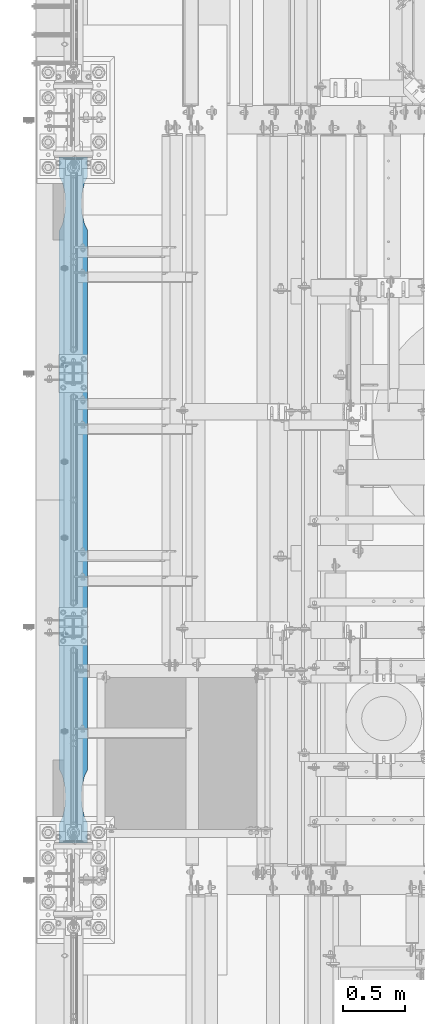
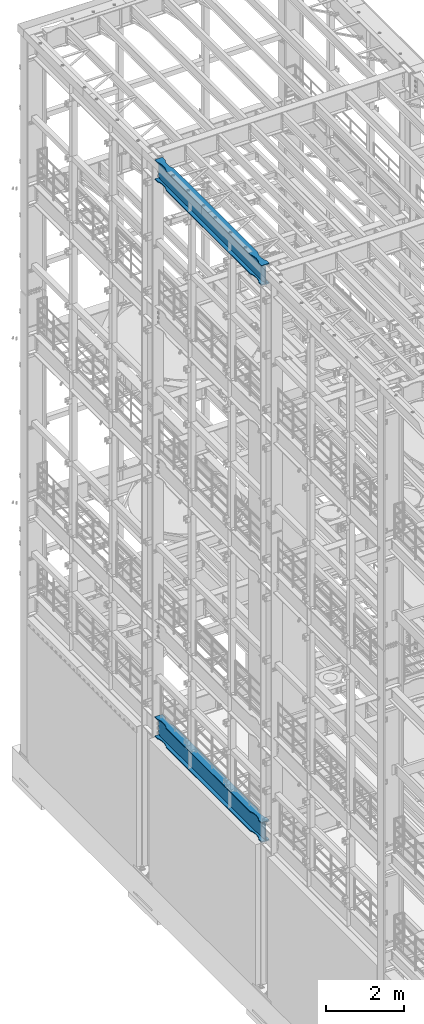
# One storey, part 1022 of 1876: 2 beams, 2 elements without a shape of their own.
"""IFC2X3 building model written with IfcOpenShell, lengths in millimetres."""

from ifc_helpers import new_model, si_unit, frame, origin_with_axes, place, context, subcontext, project, spatial, faceted_brep, material, type_object, element, aggregate, save


model = new_model("IFC2X3")

# Units and contexts
model_context = context("Model", 3, precision=1e-05, world=origin_with_axes())
body_context = subcontext(model_context, "Body", "Model", "MODEL_VIEW")
ifc_project = project(units=[si_unit("LENGTHUNIT", "METRE", prefix="MILLI"), si_unit("AREAUNIT", "SQUARE_METRE"), si_unit("VOLUMEUNIT", "CUBIC_METRE"), si_unit("MASSUNIT", "GRAM", prefix="KILO"), si_unit("TIMEUNIT", "SECOND"), si_unit("PLANEANGLEUNIT", "RADIAN"), si_unit("SOLIDANGLEUNIT", "STERADIAN"), si_unit("THERMODYNAMICTEMPERATUREUNIT", "DEGREE_CELSIUS"), si_unit("LUMINOUSINTENSITYUNIT", "LUMEN")], contexts=[model_context])

# Site, building, storey
site_placement = place(None, origin_with_axes())
site = spatial("IfcSite", under=ifc_project, at=site_placement, CompositionType="ELEMENT")
building_placement = place(site_placement, origin_with_axes())
building = spatial("IfcBuilding", under=site, at=building_placement, Name="Undefined", CompositionType="ELEMENT")
storey_placement = place(building_placement, origin_with_axes())
storey = spatial("IfcBuildingStorey", under=building, at=storey_placement, Name="Undefined", CompositionType="ELEMENT", Elevation=0.0)

# Assembly, beam
assembly_1_placement = place(storey_placement, origin_with_axes())
assembly_1 = element("IfcElementAssembly", 1, at=assembly_1_placement, inside=storey, Name="BEAM", AssemblyPlace="NOTDEFINED", PredefinedType="RIGID_FRAME")
ifc_material = material(Name="STEEL/A992")
beam_type = type_object("IfcBeamType", Name="W24X103", PredefinedType="NOTDEFINED")
beam_1_placement = place(assembly_1_placement, frame((0.0, 1524.0, 22244.05), z_axis=(0.0, 0.0, 1.0), x_axis=(0.0, 1.0, 0.0)))
beam_1 = element("IfcBeam", 2, at=beam_1_placement, type_object=beam_type, material=ifc_material, Name="BEAM", ObjectType="W24X103", context=body_context, shape_type="Brep", body=[
    faceted_brep([(306.3875, 7.14375, -250.825000000001), (298.45, -7.14375, -250.825000000001), (298.45, -7.14375, 250.825000000001), (306.3875, 7.14375, 250.825000000001), (5789.6125, 7.14375, 250.825000000001), (5797.55, -7.14375, 250.825000000001), (5797.55, -7.14375, -250.825000000001), (5789.6125, 7.14375, -250.825000000001), (5210.175, -114.3, -311.150000000001), (5210.175, -114.3, -285.75), (885.825008761703, -114.300009625517, -285.75), (885.825008761703, -114.3, -311.150000000001), (5259.2741470513, -88.8999992679901, -311.150000000001), (5259.2741470513, -88.8999992679901, -285.75), (5341.71315599965, -69.8863941921136, -311.150000000001), (5341.71315599965, -69.8863941921136, -285.75), (5426.0750039875, -63.5000040971918, -311.150000000001), (5426.0750039875, -63.5000040971918, -285.75), (5510.43685211057, -69.8863924058523, -311.150000000001), (5510.43685211057, -69.8863924058523, -285.75), (5592.87586146151, -88.8999957361821, -311.150000000001), (5592.87586146151, -88.8999957361821, -285.75), (5641.97500876196, -114.299992330618, -285.75), (5641.97500876196, -114.3, -311.150000000001), (5797.55, -114.3, -311.150000000001), (5782.88540094246, -114.299999277079, -285.75), (5210.175, -114.3, 285.75), (5210.175, -114.3, 311.150000000001), (885.825008761703, -114.300009625517, 311.150000000001), (885.825008761703, -114.3, 285.75), (5259.2741470513, -88.8999992679901, 285.75), (5259.2741470513, -88.8999992679901, 311.150000000001), (5341.71315599965, -69.8863941921136, 285.75), (5341.71315599965, -69.8863941921136, 311.150000000001), (5426.0750039875, -63.5000040971918, 285.75), (5426.0750039875, -63.5000040971918, 311.150000000001), (5510.43685211057, -69.8863924058523, 285.75), (5510.43685211057, -69.8863924058523, 311.150000000001), (5592.87586146151, -88.8999957361821, 285.75), (5592.87586146151, -88.8999957361821, 311.150000000001), (5641.97500876196, -114.299992330618, 311.150000000001), (5641.97500876196, -114.3, 285.75), (5797.55, -114.3, 285.75), (5782.88541369173, -114.29999927708, 311.150000000001), (5749.09000317383, -7.14375000000018, -285.35299987793), (5749.09000317383, 7.14375000000018, -285.35299987793), (5713.61774885072, 7.14375000000018, -269.000062630286), (5713.61774885072, -7.14375000000018, -269.000062630286), (5709.72754094452, 7.14375000000018, -265.703842989446), (5709.72754094452, -7.14375000000018, -265.703842989446), (5708.09487519741, 7.14375000000018, -260.873399528195), (5708.09487519741, -7.14375000000018, -260.873399528195), (5709.18761637614, 7.14375000000018, -255.89296800167), (5709.18761637614, -7.14375000000018, -255.89296800167), (5712.69262316711, 7.14375000000018, -252.189765486371), (5712.69262316711, -7.14375000000018, -252.189765486371), (5717.60548349907, 7.14375000000018, -250.825000000001), (5717.60548349907, -7.14375000000018, -250.825000000001), (5718.44048546451, 7.14375000000018, 250.825000000001), (5718.44048546451, -7.14375000000018, 250.825000000001), (5713.52762519576, 7.14375000000018, 252.189765448315), (5713.52762519576, -7.14375000000018, 252.189765448315), (5710.02261841062, 7.14375000000018, 255.892967871263), (5710.02261841062, -7.14375000000018, 255.892967871263), (5708.92987715069, 7.14375000000018, 260.873399307191), (5708.92987715069, -7.14375000000018, 260.873399307191), (5710.56254274408, 7.14375000000018, 265.703842745359), (5710.56254274408, -7.14375000000018, 265.703842745359), (5714.45275048114, 7.14375000000018, 269.000062475843), (5714.45275048114, -7.14375000000018, 269.000062475843), (5749.92500152588, 7.14375000000018, 285.35299987793), (5749.92500152588, -7.14375000000018, 285.35299987793), (5797.55, 7.14375000000018, 285.35299987793), (5797.55, -7.14375000000018, 285.35299987793), (5797.55, 7.14375000000018, 285.75), (5797.55, -7.14375000000018, 285.75), (5210.175, 114.3, 311.150000000001), (5210.175, 114.3, 285.75), (885.825008761703, 114.3, 285.75), (885.825008761703, 114.299990374483, 311.150000000001), (5259.2741470513, 88.8999992679901, 311.150000000001), (5259.2741470513, 88.8999992679901, 285.75), (5341.71315599965, 69.8863941921136, 311.150000000001), (5341.71315599965, 69.8863941921136, 285.75), (5426.0750039875, 63.5000040971918, 311.150000000001), (5426.0750039875, 63.5000040971918, 285.75), (5510.43685211057, 69.8863924058523, 311.150000000001), (5510.43685211057, 69.8863924058523, 285.75), (5592.87586146151, 88.8999957361821, 311.150000000001), (5592.87586146151, 88.8999957361821, 285.75), (5641.97500876196, 114.299992330618, 311.150000000001), (5641.97500876196, 114.3, 285.75), (5782.88541369173, 114.29999927708, 311.150000000001), (5797.55, 114.3, 285.75), (298.45, 7.14375000000018, 285.75), (298.45, 114.3, 285.75), (454.024999999921, 114.3, 285.75), (503.124147300347, 88.8999861106649, 285.75), (585.563156651265, 69.8863827803352, 285.75), (669.925004774302, 63.4999944716747, 285.75), (754.286852762112, 69.8863845665965, 285.75), (836.72586171043, 88.899989642473, 285.75), (454.024999999921, 114.3, 311.150000000001), (313.114586308271, 114.3, 311.150000000001), (503.124147300347, 88.8999861106649, 311.150000000001), (585.563156651265, 69.8863827803352, 311.150000000001), (669.925004774302, 63.4999944716747, 311.150000000001), (754.286852762112, 69.8863845665965, 311.150000000001), (836.72586171043, 88.899989642473, 311.150000000001), (313.114586308271, -114.3, 311.150000000001), (454.024999999921, -114.3, 311.150000000001), (503.124147300347, -88.9000053616992, 311.150000000001), (585.563156651265, -69.8864020313695, 311.150000000001), (669.925004774302, -63.5000137227089, 311.150000000001), (754.286852762112, -69.8864038176307, 311.150000000001), (836.72586171043, -88.9000088935072, 311.150000000001), (454.024999999921, -114.3, 285.75), (298.45, -114.3, 285.75), (503.124147300347, -88.9000053616992, 285.75), (585.563156651265, -69.8864020313695, 285.75), (669.925004774302, -63.5000137227089, 285.75), (754.286852762112, -69.8864038176307, 285.75), (836.72586171043, -88.9000088935072, 285.75), (298.45, -7.14375000000018, 285.75), (298.45, 7.14375000000018, 285.35299987793), (298.45, -7.14375000000018, 285.35299987793), (346.074998474121, 7.14375000000018, 285.35299987793), (346.074998474121, -7.14375000000018, 285.35299987793), (381.547249518856, 7.14375000000018, 269.000062475843), (381.547249518856, -7.14375000000018, 269.000062475843), (385.437457255921, 7.14375000000018, 265.703842745359), (385.437457255921, -7.14375000000018, 265.703842745359), (387.070122849314, 7.14375000000018, 260.873399307191), (387.070122849314, -7.14375000000018, 260.873399307191), (385.977381589376, 7.14375000000018, 255.892967871263), (385.977381589376, -7.14375000000018, 255.892967871263), (382.472374804242, 7.14375000000018, 252.189765448315), (382.472374804242, -7.14375000000018, 252.189765448315), (377.559514535493, 7.14375000000018, 250.825000000001), (377.559514535493, -7.14375000000018, 250.825000000001), (378.39451650093, 7.14375000000018, -250.825000000001), (378.39451650093, -7.14375000000018, -250.825000000001), (383.307376832887, 7.14375000000018, -252.189765486371), (383.307376832887, -7.14375000000018, -252.189765486371), (386.81238362386, 7.14375000000018, -255.89296800167), (386.81238362386, -7.14375000000018, -255.89296800167), (387.905124802588, 7.14375000000018, -260.873399528195), (387.905124802588, -7.14375000000018, -260.873399528195), (386.272459055476, 7.14375000000018, -265.703842989446), (386.272459055476, -7.14375000000018, -265.703842989446), (382.382251149282, 7.14375000000018, -269.000062630286), (382.382251149282, -7.14375000000018, -269.000062630286), (346.909996826172, 7.14375000000018, -285.35299987793), (346.909996826172, -7.14375000000018, -285.35299987793), (313.343799385621, 7.14375000000018, -285.35299987793), (313.343799385621, -7.14375000000018, -285.35299987793), (313.114599057541, -7.14375000000018, -285.75), (5782.88540094246, -7.14375000000018, -285.75), (5782.65620061438, -7.14375000000018, -285.35299987793), (5782.65620061438, 7.14375000000018, -285.35299987793), (5782.88540094246, 7.14375000000018, -285.75), (313.114599057541, 7.14375000000018, -285.75), (313.11459905754, 114.3, -285.75), (298.45, 114.3, -311.150000000001), (298.45, -114.3, -311.150000000001), (313.11459905754, -114.3, -285.75), (454.024999999921, -114.3, -311.150000000001), (454.024999999921, -114.3, -285.75), (503.124147300347, -88.9000053616992, -311.150000000001), (503.124147300347, -88.9000053616992, -285.75), (585.563156651265, -69.8864020313695, -311.150000000001), (585.563156651265, -69.8864020313695, -285.75), (669.925004774302, -63.5000137227089, -311.150000000001), (669.925004774302, -63.5000137227089, -285.75), (754.286852762112, -69.8864038176307, -311.150000000001), (754.286852762112, -69.8864038176307, -285.75), (836.72586171043, -88.9000088935072, -285.75), (5797.55, 114.3, -311.150000000001), (5782.88540094246, 114.299999277079, -285.75), (5641.97500876196, 114.3, -311.150000000001), (5641.97500876196, 114.299992330618, -285.75), (5592.87586146151, 88.8999957361821, -311.150000000001), (5592.87586146151, 88.8999957361821, -285.75), (5510.43685211057, 69.8863924058523, -311.150000000001), (5510.43685211057, 69.8863924058523, -285.75), (5426.0750039875, 63.5000040971918, -311.150000000001), (5426.0750039875, 63.5000040971918, -285.75), (5341.71315599965, 69.8863941921136, -311.150000000001), (5341.71315599965, 69.8863941921136, -285.75), (5259.2741470513, 88.8999992679901, -311.150000000001), (5259.2741470513, 88.8999992679901, -285.75), (5210.175, 114.3, -311.150000000001), (5210.175, 114.3, -285.75), (885.825008761703, 114.3, -311.150000000001), (885.825008761703, 114.299990374483, -285.75), (836.72586171043, 88.899989642473, -285.75), (754.286852762112, 69.8863845665965, -285.75), (669.925004774302, 63.4999944716747, -285.75), (585.563156651265, 69.8863827803352, -285.75), (503.124147300347, 88.8999861106649, -285.75), (454.024999999921, 114.3, -285.75), (454.024999999921, 114.3, -311.150000000001), (503.124147300347, 88.8999861106649, -311.150000000001), (585.563156651265, 69.8863827803352, -311.150000000001), (669.925004774302, 63.4999944716747, -311.150000000001), (754.286852762112, 69.8863845665965, -311.150000000001), (836.72586171043, 88.899989642473, -311.150000000001), (836.72586171043, -88.9000088935072, -311.150000000001)], [[[0, 1, 2, 3]], [[4, 5, 6, 7]], [[8, 9, 10, 11]], [[9, 8, 12, 13]], [[13, 12, 14, 15]], [[15, 14, 16, 17]], [[17, 16, 18, 19]], [[19, 18, 20, 21]], [[22, 21, 20, 23]], [[22, 23, 24, 25]], [[26, 27, 28, 29]], [[27, 26, 30, 31]], [[31, 30, 32, 33]], [[33, 32, 34, 35]], [[35, 34, 36, 37]], [[37, 36, 38, 39]], [[40, 39, 38, 41]], [[40, 41, 42, 43]], [[44, 45, 46, 47]], [[47, 46, 48, 49]], [[49, 48, 50, 51]], [[51, 50, 52, 53]], [[53, 52, 54, 55]], [[55, 54, 56, 57]], [[57, 56, 7, 6]], [[58, 59, 5, 4]], [[59, 58, 60, 61]], [[61, 60, 62, 63]], [[63, 62, 64, 65]], [[65, 64, 66, 67]], [[67, 66, 68, 69]], [[69, 68, 70, 71]], [[71, 70, 72, 73]], [[73, 72, 74, 75]], [[76, 77, 78, 79]], [[80, 81, 77, 76]], [[82, 83, 81, 80]], [[84, 85, 83, 82]], [[86, 87, 85, 84]], [[88, 89, 87, 86]], [[90, 91, 89, 88]], [[91, 90, 92, 93]], [[42, 75, 74, 93, 92, 43]], [[94, 95, 96, 97, 98, 99, 100, 101, 78, 77, 81, 83, 85, 87, 89, 91, 93, 74]], [[102, 96, 95, 103]], [[104, 97, 96, 102]], [[105, 98, 97, 104]], [[106, 99, 98, 105]], [[107, 100, 99, 106]], [[108, 101, 100, 107]], [[79, 78, 101, 108]], [[90, 88, 86, 84, 82, 80, 76, 79, 108, 107, 106, 105, 104, 102, 103, 109, 110, 111, 112, 113, 114, 115, 28, 27, 31, 33, 35, 37, 39, 40, 43, 92]], [[116, 110, 109, 117]], [[110, 116, 118, 111]], [[111, 118, 119, 112]], [[112, 119, 120, 113]], [[113, 120, 121, 114]], [[114, 121, 122, 115]], [[28, 115, 122, 29]], [[41, 38, 36, 34, 32, 30, 26, 29, 122, 121, 120, 119, 118, 116, 117, 123, 75, 42]], [[109, 103, 95, 94, 123, 117]], [[124, 125, 123, 94]], [[126, 127, 125, 124]], [[127, 126, 128, 129]], [[129, 128, 130, 131]], [[131, 130, 132, 133]], [[133, 132, 134, 135]], [[135, 134, 136, 137]], [[137, 136, 138, 139]], [[139, 138, 3, 2]], [[140, 141, 1, 0]], [[141, 140, 142, 143]], [[143, 142, 144, 145]], [[145, 144, 146, 147]], [[147, 146, 148, 149]], [[149, 148, 150, 151]], [[151, 150, 152, 153]], [[153, 152, 154, 155]], [[44, 47, 49, 51, 53, 55, 57, 6, 5, 59, 61, 63, 65, 67, 69, 71, 73, 75, 123, 125, 127, 129, 131, 133, 135, 137, 139, 2, 1, 141, 143, 145, 147, 149, 151, 153, 155, 156, 157, 158]], [[45, 44, 158, 159]], [[138, 136, 134, 132, 130, 128, 126, 124, 94, 74, 72, 70, 68, 66, 64, 62, 60, 58, 4, 7, 56, 54, 52, 50, 48, 46, 45, 159, 160, 161, 154, 152, 150, 148, 146, 144, 142, 140, 0, 3]], [[155, 154, 161, 162, 163, 164, 165, 156]], [[166, 167, 165, 164]], [[167, 166, 168, 169]], [[169, 168, 170, 171]], [[171, 170, 172, 173]], [[173, 172, 174, 175]], [[156, 165, 167, 169, 171, 173, 175, 176, 10, 9, 13, 15, 17, 19, 21, 22, 25, 157]], [[24, 177, 178, 160, 159, 158, 157, 25]], [[179, 180, 178, 177]], [[180, 179, 181, 182]], [[182, 181, 183, 184]], [[184, 183, 185, 186]], [[186, 185, 187, 188]], [[188, 187, 189, 190]], [[190, 189, 191, 192]], [[192, 191, 193, 194]], [[180, 182, 184, 186, 188, 190, 192, 194, 195, 196, 197, 198, 199, 200, 162, 161, 160, 178]], [[200, 201, 163, 162]], [[199, 202, 201, 200]], [[198, 203, 202, 199]], [[197, 204, 203, 198]], [[196, 205, 204, 197]], [[195, 206, 205, 196]], [[194, 193, 206, 195]], [[23, 20, 18, 16, 14, 12, 8, 11, 207, 174, 172, 170, 168, 166, 164, 163, 201, 202, 203, 204, 205, 206, 193, 191, 189, 187, 185, 183, 181, 179, 177, 24]], [[10, 176, 207, 11]], [[175, 174, 207, 176]]]),
])
aggregate(assembly_1, [beam_1])

assembly_2_placement = place(storey_placement, origin_with_axes())
assembly_2 = element("IfcElementAssembly", 3, at=assembly_2_placement, inside=storey, Name="BEAM", AssemblyPlace="NOTDEFINED", PredefinedType="RIGID_FRAME")
beam_2_placement = place(assembly_2_placement, frame((0.0, 1524.0, 4819.65), z_axis=(0.0, 0.0, 1.0), x_axis=(0.0, 1.0, 0.0)))
beam_2 = element("IfcBeam", 4, at=beam_2_placement, type_object=beam_type, material=ifc_material, Name="BEAM", ObjectType="W24X103", context=body_context, shape_type="Brep", body=[
    faceted_brep([(306.3875, 7.14375, -250.825000000001), (298.45, -7.14375, -250.825000000001), (298.45, -7.14375, 250.825000000001), (306.3875, 7.14375, 250.825000000001), (5789.6125, 7.14375, 250.825000000001), (5797.55, -7.14375, 250.825000000001), (5797.55, -7.14375, -250.825000000001), (5789.6125, 7.14375, -250.825000000001), (313.114586308271, -114.3, 311.150000000001), (313.114586308271, 114.3, 311.150000000001), (298.45, 114.3, 285.75), (298.45, 7.14375000000018, 285.75), (298.45, -7.14375000000018, 285.75), (298.45, -114.3, 285.75), (503.124147300347, 88.8999861106649, -285.75), (503.124147300347, 88.8999861106649, -311.150000000001), (454.024999999921, 114.3, -311.150000000001), (454.024999999921, 114.3, -285.75), (585.563156651265, 69.8863827803352, -285.75), (585.563156651265, 69.8863827803352, -311.150000000001), (669.925004774302, 63.4999944716747, -285.75), (669.925004774302, 63.4999944716747, -311.150000000001), (754.286852762112, 69.8863845665965, -285.75), (754.286852762112, 69.8863845665965, -311.150000000001), (836.72586171043, 88.899989642473, -285.75), (836.72586171043, 88.899989642473, -311.150000000001), (885.825008761703, 114.299990374483, -285.75), (885.825008761703, 114.3, -311.150000000001), (5210.175, 114.3, -285.75), (5210.175, 114.3, -311.150000000001), (5259.2741470513, 88.8999992679901, -285.75), (5259.2741470513, 88.8999992679901, -311.150000000001), (5341.71315599965, 69.8863941921136, -285.75), (5341.71315599965, 69.8863941921136, -311.150000000001), (5426.0750039875, 63.5000040971918, -285.75), (5426.0750039875, 63.5000040971918, -311.150000000001), (5510.43685211057, 69.8863924058523, -285.75), (5510.43685211057, 69.8863924058523, -311.150000000001), (5592.87586146151, 88.8999957361821, -285.75), (5592.87586146151, 88.8999957361821, -311.150000000001), (5641.97500876196, 114.299992330618, -285.75), (5641.97500876196, 114.3, -311.150000000001), (5782.88540094246, 114.299999277079, -285.75), (5797.55, 114.3, -311.150000000001), (5641.97500876196, -114.299992330618, -285.75), (5641.97500876196, -114.3, -311.150000000001), (5797.55, -114.3, -311.150000000001), (5782.88540094246, -114.299999277079, -285.75), (5592.87586146151, -88.8999957361821, -285.75), (5592.87586146151, -88.8999957361821, -311.150000000001), (5510.43685211057, -69.8863924058523, -285.75), (5510.43685211057, -69.8863924058523, -311.150000000001), (5426.0750039875, -63.5000040971918, -285.75), (5426.0750039875, -63.5000040971918, -311.150000000001), (5341.71315599965, -69.8863941921136, -285.75), (5341.71315599965, -69.8863941921136, -311.150000000001), (5259.2741470513, -88.8999992679901, -285.75), (5259.2741470513, -88.8999992679901, -311.150000000001), (5210.175, -114.3, -285.75), (5210.175, -114.3, -311.150000000001), (885.825008761703, -114.300009625517, -285.75), (885.825008761703, -114.3, -311.150000000001), (836.72586171043, -88.9000088935072, -285.75), (836.72586171043, -88.9000088935072, -311.150000000001), (754.286852762112, -69.8864038176307, -285.75), (754.286852762112, -69.8864038176307, -311.150000000001), (669.925004774302, -63.5000137227089, -285.75), (669.925004774302, -63.5000137227089, -311.150000000001), (585.563156651265, -69.8864020313695, -285.75), (585.563156651265, -69.8864020313695, -311.150000000001), (503.124147300347, -88.9000053616992, -285.75), (503.124147300347, -88.9000053616992, -311.150000000001), (454.024999999921, -114.3, -285.75), (454.024999999921, -114.3, -311.150000000001), (313.11459905754, -114.3, -285.75), (298.45, -114.3, -311.150000000001), (298.45, 114.3, -311.150000000001), (313.11459905754, 114.3, -285.75), (313.114599057541, 7.14375000000018, -285.75), (5782.88540094246, 7.14375000000018, -285.75), (5782.65620061438, 7.14375000000018, -285.35299987793), (5782.65620061438, -7.14375000000018, -285.35299987793), (5782.88540094246, -7.14375000000018, -285.75), (5749.09000317383, 7.14375000000018, -285.35299987793), (5749.09000317383, -7.14375000000018, -285.35299987793), (5713.61774885072, 7.14375000000018, -269.000062630286), (5713.61774885072, -7.14375000000018, -269.000062630286), (5709.72754094452, 7.14375000000018, -265.703842989446), (5709.72754094452, -7.14375000000018, -265.703842989446), (5708.09487519741, 7.14375000000018, -260.873399528195), (5708.09487519741, -7.14375000000018, -260.873399528195), (5709.18761637614, 7.14375000000018, -255.89296800167), (5709.18761637614, -7.14375000000018, -255.89296800167), (5712.69262316711, 7.14375000000018, -252.189765486371), (5712.69262316711, -7.14375000000018, -252.189765486371), (5717.60548349907, 7.14375000000018, -250.825000000001), (5717.60548349907, -7.14375000000018, -250.825000000001), (5718.44048546451, 7.14375000000018, 250.825000000001), (5718.44048546451, -7.14375000000018, 250.825000000001), (5713.52762519576, 7.14375000000018, 252.189765448315), (5713.52762519576, -7.14375000000018, 252.189765448315), (5710.02261841062, 7.14375000000018, 255.892967871263), (5710.02261841062, -7.14375000000018, 255.892967871263), (5708.92987715069, 7.14375000000018, 260.873399307191), (5708.92987715069, -7.14375000000018, 260.873399307191), (5710.56254274408, 7.14375000000018, 265.703842745359), (5710.56254274408, -7.14375000000018, 265.703842745359), (5714.45275048114, 7.14375000000018, 269.000062475843), (5714.45275048114, -7.14375000000018, 269.000062475843), (5749.92500152588, 7.14375000000018, 285.35299987793), (5749.92500152588, -7.14375000000018, 285.35299987793), (5797.55, 7.14375000000018, 285.35299987793), (5797.55, -7.14375000000018, 285.35299987793), (5797.55, 7.14375000000018, 285.75), (5797.55, -7.14375000000018, 285.75), (503.124147300347, 88.8999861106649, 311.150000000001), (503.124147300347, 88.8999861106649, 285.75), (454.024999999921, 114.3, 285.75), (454.024999999921, 114.3, 311.150000000001), (585.563156651265, 69.8863827803352, 311.150000000001), (585.563156651265, 69.8863827803352, 285.75), (669.925004774302, 63.4999944716747, 311.150000000001), (669.925004774302, 63.4999944716747, 285.75), (754.286852762112, 69.8863845665965, 311.150000000001), (754.286852762112, 69.8863845665965, 285.75), (836.72586171043, 88.899989642473, 311.150000000001), (836.72586171043, 88.899989642473, 285.75), (885.825008761703, 114.299990374483, 311.150000000001), (885.825008761703, 114.3, 285.75), (5210.175, 114.3, 311.150000000001), (5210.175, 114.3, 285.75), (5259.2741470513, 88.8999992679901, 311.150000000001), (5259.2741470513, 88.8999992679901, 285.75), (5341.71315599965, 69.8863941921136, 311.150000000001), (5341.71315599965, 69.8863941921136, 285.75), (5426.0750039875, 63.5000040971918, 311.150000000001), (5426.0750039875, 63.5000040971918, 285.75), (5510.43685211057, 69.8863924058523, 311.150000000001), (5510.43685211057, 69.8863924058523, 285.75), (5592.87586146151, 88.8999957361821, 311.150000000001), (5592.87586146151, 88.8999957361821, 285.75), (5641.97500876196, 114.299992330618, 311.150000000001), (5641.97500876196, 114.3, 285.75), (5782.88541369173, 114.29999927708, 311.150000000001), (5797.55, 114.3, 285.75), (5797.55, -114.3, 285.75), (5782.88541369173, -114.29999927708, 311.150000000001), (5641.97500876196, -114.299992330618, 311.150000000001), (5641.97500876196, -114.3, 285.75), (5592.87586146151, -88.8999957361821, 311.150000000001), (5592.87586146151, -88.8999957361821, 285.75), (5510.43685211057, -69.8863924058523, 311.150000000001), (5510.43685211057, -69.8863924058523, 285.75), (5426.0750039875, -63.5000040971918, 311.150000000001), (5426.0750039875, -63.5000040971918, 285.75), (5341.71315599965, -69.8863941921136, 311.150000000001), (5341.71315599965, -69.8863941921136, 285.75), (5259.2741470513, -88.8999992679901, 311.150000000001), (5259.2741470513, -88.8999992679901, 285.75), (5210.175, -114.3, 311.150000000001), (5210.175, -114.3, 285.75), (885.825008761703, -114.300009625517, 311.150000000001), (885.825008761703, -114.3, 285.75), (836.72586171043, -88.9000088935072, 311.150000000001), (836.72586171043, -88.9000088935072, 285.75), (754.286852762112, -69.8864038176307, 311.150000000001), (754.286852762112, -69.8864038176307, 285.75), (669.925004774302, -63.5000137227089, 311.150000000001), (669.925004774302, -63.5000137227089, 285.75), (585.563156651265, -69.8864020313695, 311.150000000001), (585.563156651265, -69.8864020313695, 285.75), (503.124147300347, -88.9000053616992, 311.150000000001), (503.124147300347, -88.9000053616992, 285.75), (454.024999999921, -114.3, 311.150000000001), (454.024999999921, -114.3, 285.75), (298.45, 7.14375000000018, 285.35299987793), (298.45, -7.14375000000018, 285.35299987793), (346.074998474121, 7.14375000000018, 285.35299987793), (346.074998474121, -7.14375000000018, 285.35299987793), (381.547249518856, 7.14375000000018, 269.000062475843), (381.547249518856, -7.14375000000018, 269.000062475843), (385.437457255921, 7.14375000000018, 265.703842745359), (385.437457255921, -7.14375000000018, 265.703842745359), (387.070122849314, 7.14375000000018, 260.873399307191), (387.070122849314, -7.14375000000018, 260.873399307191), (385.977381589376, 7.14375000000018, 255.892967871263), (385.977381589376, -7.14375000000018, 255.892967871263), (382.472374804242, 7.14375000000018, 252.189765448315), (382.472374804242, -7.14375000000018, 252.189765448315), (377.559514535493, 7.14375000000018, 250.825000000001), (377.559514535493, -7.14375000000018, 250.825000000001), (378.39451650093, 7.14375000000018, -250.825000000001), (378.39451650093, -7.14375000000018, -250.825000000001), (383.307376832887, 7.14375000000018, -252.189765486371), (383.307376832887, -7.14375000000018, -252.189765486371), (386.81238362386, 7.14375000000018, -255.89296800167), (386.81238362386, -7.14375000000018, -255.89296800167), (387.905124802588, 7.14375000000018, -260.873399528195), (387.905124802588, -7.14375000000018, -260.873399528195), (386.272459055476, 7.14375000000018, -265.703842989446), (386.272459055476, -7.14375000000018, -265.703842989446), (382.382251149282, 7.14375000000018, -269.000062630286), (382.382251149282, -7.14375000000018, -269.000062630286), (346.909996826172, 7.14375000000018, -285.35299987793), (346.909996826172, -7.14375000000018, -285.35299987793), (313.343799385621, 7.14375000000018, -285.35299987793), (313.343799385621, -7.14375000000018, -285.35299987793), (313.114599057541, -7.14375000000018, -285.75)], [[[0, 1, 2, 3]], [[4, 5, 6, 7]], [[8, 9, 10, 11, 12, 13]], [[14, 15, 16, 17]], [[18, 19, 15, 14]], [[20, 21, 19, 18]], [[22, 23, 21, 20]], [[24, 25, 23, 22]], [[26, 27, 25, 24]], [[28, 29, 27, 26]], [[30, 31, 29, 28]], [[32, 33, 31, 30]], [[34, 35, 33, 32]], [[36, 37, 35, 34]], [[38, 39, 37, 36]], [[40, 41, 39, 38]], [[41, 40, 42, 43]], [[44, 45, 46, 47]], [[44, 48, 49, 45]], [[50, 51, 49, 48]], [[52, 53, 51, 50]], [[54, 55, 53, 52]], [[56, 57, 55, 54]], [[58, 59, 57, 56]], [[59, 58, 60, 61]], [[60, 62, 63, 61]], [[64, 65, 63, 62]], [[66, 67, 65, 64]], [[68, 69, 67, 66]], [[70, 71, 69, 68]], [[72, 73, 71, 70]], [[73, 72, 74, 75]], [[45, 49, 51, 53, 55, 57, 59, 61, 63, 65, 67, 69, 71, 73, 75, 76, 16, 15, 19, 21, 23, 25, 27, 29, 31, 33, 35, 37, 39, 41, 43, 46]], [[17, 16, 76, 77]], [[40, 38, 36, 34, 32, 30, 28, 26, 24, 22, 20, 18, 14, 17, 77, 78, 79, 42]], [[46, 43, 42, 79, 80, 81, 82, 47]], [[83, 84, 81, 80]], [[84, 83, 85, 86]], [[86, 85, 87, 88]], [[88, 87, 89, 90]], [[90, 89, 91, 92]], [[92, 91, 93, 94]], [[94, 93, 95, 96]], [[96, 95, 7, 6]], [[97, 98, 5, 4]], [[98, 97, 99, 100]], [[100, 99, 101, 102]], [[102, 101, 103, 104]], [[104, 103, 105, 106]], [[106, 105, 107, 108]], [[108, 107, 109, 110]], [[110, 109, 111, 112]], [[112, 111, 113, 114]], [[115, 116, 117, 118]], [[119, 120, 116, 115]], [[121, 122, 120, 119]], [[123, 124, 122, 121]], [[125, 126, 124, 123]], [[127, 128, 126, 125]], [[129, 130, 128, 127]], [[131, 132, 130, 129]], [[133, 134, 132, 131]], [[135, 136, 134, 133]], [[137, 138, 136, 135]], [[139, 140, 138, 137]], [[141, 142, 140, 139]], [[142, 141, 143, 144]], [[145, 114, 113, 144, 143, 146]], [[147, 148, 145, 146]], [[147, 149, 150, 148]], [[151, 152, 150, 149]], [[153, 154, 152, 151]], [[155, 156, 154, 153]], [[157, 158, 156, 155]], [[159, 160, 158, 157]], [[160, 159, 161, 162]], [[161, 163, 164, 162]], [[165, 166, 164, 163]], [[167, 168, 166, 165]], [[169, 170, 168, 167]], [[171, 172, 170, 169]], [[173, 174, 172, 171]], [[174, 173, 8, 13]], [[148, 150, 152, 154, 156, 158, 160, 162, 164, 166, 168, 170, 172, 174, 13, 12, 114, 145]], [[175, 176, 12, 11]], [[177, 178, 176, 175]], [[178, 177, 179, 180]], [[180, 179, 181, 182]], [[182, 181, 183, 184]], [[184, 183, 185, 186]], [[186, 185, 187, 188]], [[188, 187, 189, 190]], [[190, 189, 3, 2]], [[191, 192, 1, 0]], [[192, 191, 193, 194]], [[194, 193, 195, 196]], [[196, 195, 197, 198]], [[198, 197, 199, 200]], [[200, 199, 201, 202]], [[202, 201, 203, 204]], [[204, 203, 205, 206]], [[84, 86, 88, 90, 92, 94, 96, 6, 5, 98, 100, 102, 104, 106, 108, 110, 112, 114, 12, 176, 178, 180, 182, 184, 186, 188, 190, 2, 1, 192, 194, 196, 198, 200, 202, 204, 206, 207, 82, 81]], [[207, 74, 72, 70, 68, 66, 64, 62, 60, 58, 56, 54, 52, 50, 48, 44, 47, 82]], [[206, 205, 78, 77, 76, 75, 74, 207]], [[189, 187, 185, 183, 181, 179, 177, 175, 11, 113, 111, 109, 107, 105, 103, 101, 99, 97, 4, 7, 95, 93, 91, 89, 87, 85, 83, 80, 79, 78, 205, 203, 201, 199, 197, 195, 193, 191, 0, 3]], [[11, 10, 117, 116, 120, 122, 124, 126, 128, 130, 132, 134, 136, 138, 140, 142, 144, 113]], [[118, 117, 10, 9]], [[141, 139, 137, 135, 133, 131, 129, 127, 125, 123, 121, 119, 115, 118, 9, 8, 173, 171, 169, 167, 165, 163, 161, 159, 157, 155, 153, 151, 149, 147, 146, 143]]]),
])
aggregate(assembly_2, [beam_2])

save(model, "model.ifc")
